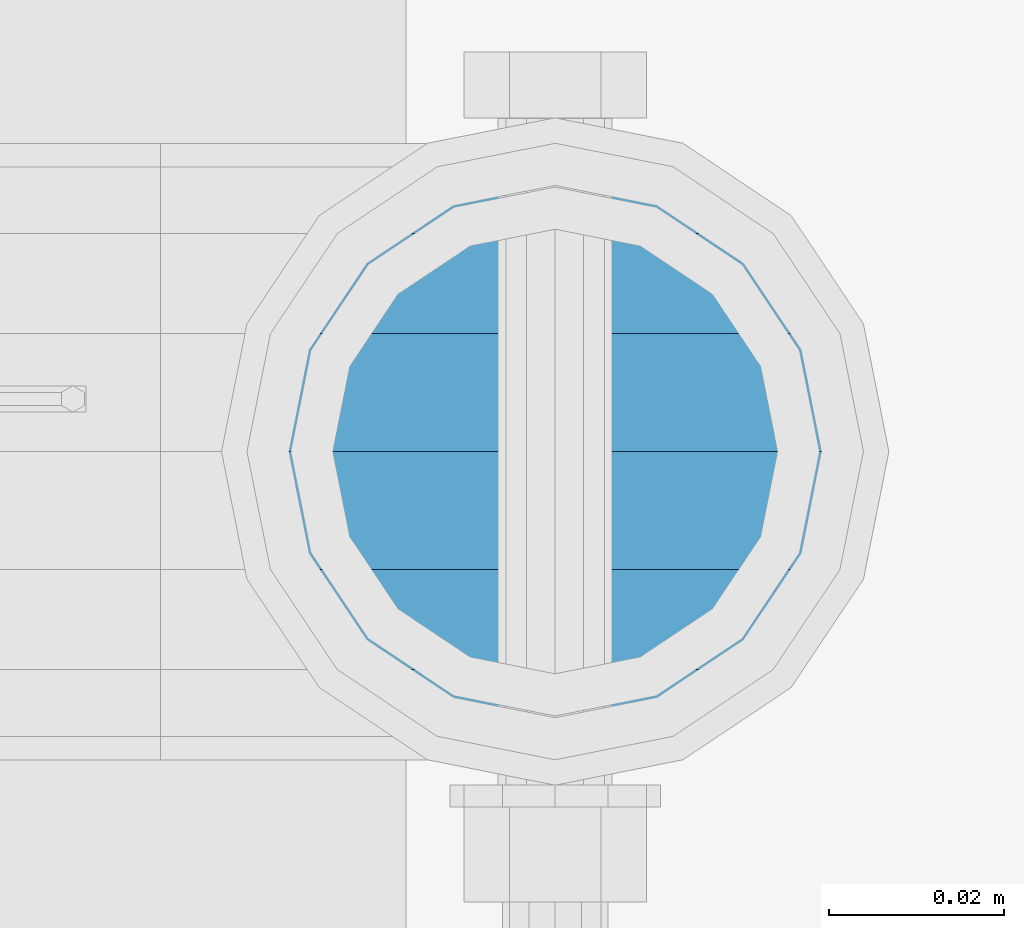
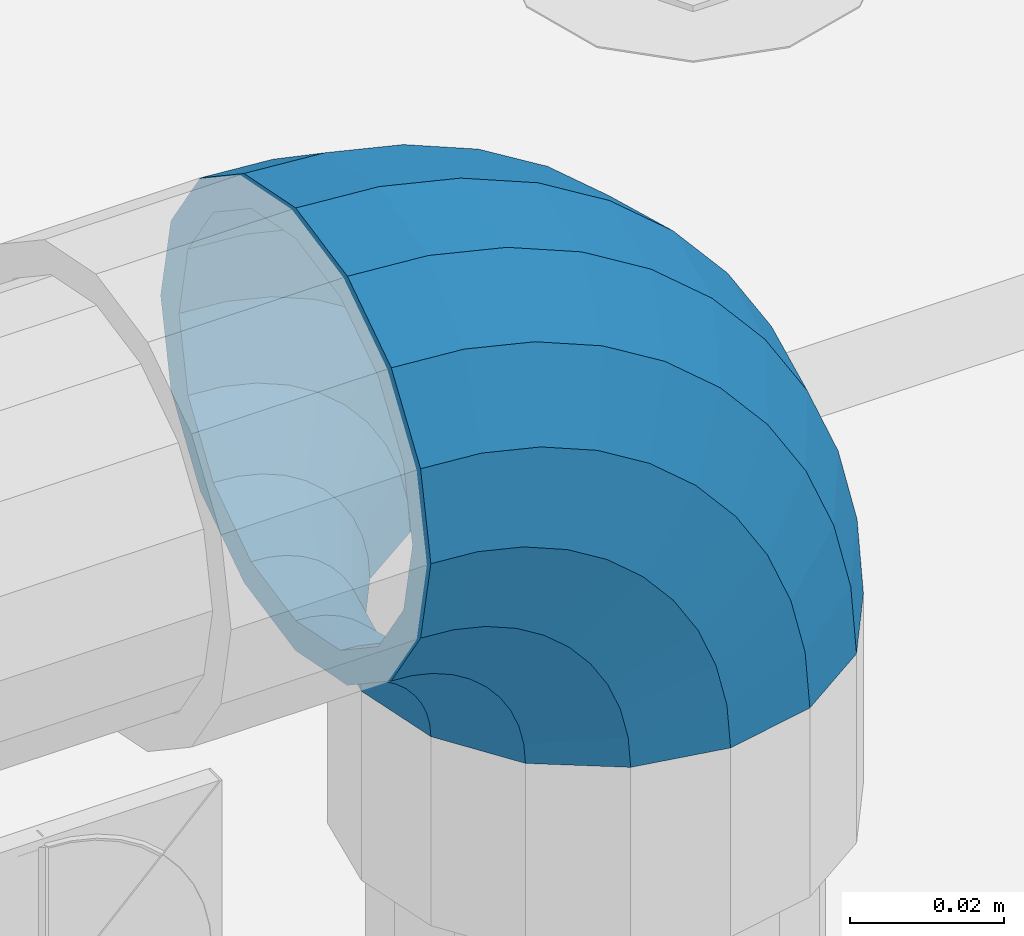
# One storey, part 126 of 193: 1 member.
"""IFC2X3 building model written with IfcOpenShell, lengths in millimetres."""

import ifcopenshell
import ifcopenshell.guid

model = None  # the IFC model being written
_history = None  # IfcOwnerHistory: only IFC2X3 demands one
_inside = {}  # id of a spatial element -> (the spatial element, [elements in it])
_under = {}  # id of a project, library or spatial element -> (it, [spatial elements below it])
_declared = {}  # id of a project -> (the project, [libraries it declares])
_typed = {}  # id of a type object -> (the type object, [elements of that type])
_made_of = {}  # id of a material, layer set ... -> (it, [elements and type objects made of it])


def new_model(schema):
    """Start an empty IFC model of exactly this schema.

    Asked for "IFC4X3", IfcOpenShell would pick the latest addendum, in which some entities
    have other attributes; the version numbers below select the first issue.
    IFC2X3 requires an IfcOwnerHistory on every rooted entity: one is made here for all.
    """
    global model, _history
    if schema == "IFC4X3":
        model = ifcopenshell.file(schema_version=(4, 3, 0, 0))
    else:
        model = ifcopenshell.file(schema=schema)
    _inside.clear()
    _under.clear()
    _declared.clear()
    _typed.clear()
    _made_of.clear()
    _history = None
    if model.schema == "IFC2X3":
        org = make("IfcOrganization", Name="unknown")
        user = make(
            "IfcPersonAndOrganization",
            ThePerson=make("IfcPerson", FamilyName="unknown"),
            TheOrganization=org,
        )
        app = make(
            "IfcApplication",
            ApplicationDeveloper=org,
            Version="unknown",
            ApplicationFullName="unknown",
            ApplicationIdentifier="unknown",
        )
        _history = make(
            "IfcOwnerHistory",
            OwningUser=user,
            OwningApplication=app,
            ChangeAction="ADDED",
            CreationDate=0,
        )
    return model


def make(cls, **values):
    """One entity of the class cls with the attributes given. An attribute that is None is left unset."""
    return model.create_entity(
        cls, **{name: value for name, value in values.items() if value is not None}
    )


def rooted(cls, **values):
    """An entity with a GlobalId (a new one), such as an element, a storey or a relation."""
    return make(cls, GlobalId=ifcopenshell.guid.new(), OwnerHistory=_history, **values)


def si_unit(unit_type, name, prefix=None):
    """IfcSIUnit, for example si_unit("LENGTHUNIT", "METRE", prefix="MILLI")."""
    return make("IfcSIUnit", UnitType=unit_type, Prefix=prefix, Name=name)


def assignment(units):
    """IfcUnitAssignment: the units of a project."""
    return None if units is None else make("IfcUnitAssignment", Units=units)


def point(xyz):
    """IfcCartesianPoint."""
    return None if xyz is None else make("IfcCartesianPoint", Coordinates=xyz)


def direction(xyz):
    """IfcDirection."""
    return None if xyz is None else make("IfcDirection", DirectionRatios=xyz)


def frame(location, z_axis=None, x_axis=None):
    """IfcAxis2Placement3D, a coordinate frame: its origin and axes. An axis left out is left unset."""
    return make(
        "IfcAxis2Placement3D",
        Location=point(location),
        Axis=direction(z_axis),
        RefDirection=direction(x_axis),
    )


def origin_with_axes():
    """The frame at (0, 0, 0) with the z axis (0, 0, 1) and the x axis (1, 0, 0) written out."""
    return frame((0.0, 0.0, 0.0), z_axis=(0.0, 0.0, 1.0), x_axis=(1.0, 0.0, 0.0))


def place(relative_to, where):
    """IfcLocalPlacement: puts the frame where relative to a parent placement (None: the world)."""
    return make(
        "IfcLocalPlacement", PlacementRelTo=relative_to, RelativePlacement=where
    )


def context(
    kind, dimensions, precision=None, world=None, true_north=None, identifier=None
):
    """IfcGeometricRepresentationContext, for example the 3D "Model" context."""
    return make(
        "IfcGeometricRepresentationContext",
        ContextIdentifier=identifier,
        ContextType=kind,
        CoordinateSpaceDimension=dimensions,
        Precision=precision,
        WorldCoordinateSystem=world,
        TrueNorth=true_north,
    )


def subcontext(parent, identifier, kind, view, scale=None):
    """IfcGeometricRepresentationSubContext, for example "Body" below "Model"."""
    return make(
        "IfcGeometricRepresentationSubContext",
        ContextIdentifier=identifier,
        ContextType=kind,
        ParentContext=parent,
        TargetScale=scale,
        TargetView=view,
    )


def project(units=None, contexts=None):
    """IfcProject with its units and contexts."""
    return rooted(
        "IfcProject",
        Name="project",
        RepresentationContexts=contexts,
        UnitsInContext=assignment(units),
    )


def spatial(cls, under=None, at=None, **own):
    """A site, building, storey or space (cls), placed at a placement, below another one or the project."""
    s = rooted(cls, ObjectPlacement=at, **own)
    if under is not None:
        _under.setdefault(under.id(), (under, []))[1].append(s)
    return s


def faces_of(points, faces, orient=None, outer=None):
    """IfcFace entities. A face is a list of loops; a loop is a list of indices into points, from 0.

    orient and outer hold one flag for each loop. By default every Orientation is true, the
    first loop of a face is its IfcFaceOuterBound and the others are IfcFaceBound.
    """
    made = []
    for i, loops in enumerate(faces):
        bounds = []
        for j, loop in enumerate(loops):
            is_outer = j == 0 if outer is None else outer[i][j]
            bounds.append(
                make(
                    "IfcFaceOuterBound" if is_outer else "IfcFaceBound",
                    Bound=make("IfcPolyLoop", Polygon=[points[k] for k in loop]),
                    Orientation=True if orient is None else orient[i][j],
                )
            )
        made.append(make("IfcFace", Bounds=bounds))
    return made


def faceted_brep(points, faces, orient=None, outer=None, voids=None):
    """IfcFacetedBrep: a solid bounded by flat faces; with voids (closed shells), ...WithVoids."""
    shared = [point(p) for p in points]
    hull = make("IfcClosedShell", CfsFaces=faces_of(shared, faces, orient, outer))
    if voids is None:
        return make("IfcFacetedBrep", Outer=hull)
    return make(
        "IfcFacetedBrepWithVoids",
        Outer=hull,
        Voids=[
            make(cls, CfsFaces=faces_of(shared, fs, o, b)) for cls, fs, o, b in voids
        ],
    )


def shape(context_of_items, identifier, shape_type, items):
    """IfcShapeRepresentation: the items that make up one representation, for example the "Body"."""
    return make(
        "IfcShapeRepresentation",
        ContextOfItems=context_of_items,
        RepresentationIdentifier=identifier,
        RepresentationType=shape_type,
        Items=items,
    )


def material(Name=None, Category=None):
    """IfcMaterial."""
    return make("IfcMaterial", Name=Name, Category=Category)


def made_of(thing, what):
    """Note that an element or type object is made of a material, layer set ...; save() writes the relation."""
    if what is not None:
        _made_of.setdefault(what.id(), (what, []))[1].append(thing)
    return thing


def type_object(cls, material=None, **own):
    """A type object (cls), such as IfcWallType, which elements share."""
    return made_of(rooted(cls, **own), material)


def element(
    cls,
    number,
    at=None,
    inside=None,
    cuts=None,
    type_object=None,
    material=None,
    context=None,
    identifier="Body",
    shape_type=None,
    held_by="IfcProductDefinitionShape",
    body=None,
    shapes=None,
    **own,
):
    """One element of the class cls, such as IfcWall. Its Tag is "e" and its number.

    at: its placement. inside: the storey or other place that contains it. cuts: it is an
    opening in that element (IfcRelVoidsElement). A single representation is given by context,
    identifier, shape_type and body (its items); several are given by shapes. held_by: the class
    of the entity that holds the representations. save() writes the other relations.
    """
    e = rooted(cls, Tag="e%d" % number, ObjectPlacement=at, **own)
    if body is not None:
        shapes = [shape(context, identifier, shape_type, body)]
    if shapes is not None:
        e.Representation = make(held_by, Representations=shapes)
    if inside is not None:
        _inside.setdefault(inside.id(), (inside, []))[1].append(e)
    if cuts is not None:
        rooted(
            "IfcRelVoidsElement", RelatingBuildingElement=cuts, RelatedOpeningElement=e
        )
    if type_object is not None:
        _typed.setdefault(type_object.id(), (type_object, []))[1].append(e)
    return made_of(e, material)


def aggregate(whole, parts):
    """IfcRelAggregates: a whole, such as a stair, and the parts it consists of."""
    return rooted("IfcRelAggregates", RelatingObject=whole, RelatedObjects=parts)


def save(model, path):
    """Write the relations noted so far, then the file.

    IfcRelAggregates (storeys below a building ...), IfcRelContainedInSpatialStructure (elements
    in a storey), IfcRelDefinesByType, IfcRelAssociatesMaterial and IfcRelDeclares: one each for
    every whole, place, type object, material and project.
    """
    for whole, parts in _under.values():
        aggregate(whole, parts)
    for where, things in _inside.values():
        rooted(
            "IfcRelContainedInSpatialStructure",
            RelatedElements=things,
            RelatingStructure=where,
        )
    for kind, things in _typed.values():
        rooted("IfcRelDefinesByType", RelatedObjects=things, RelatingType=kind)
    for what, things in _made_of.values():
        rooted("IfcRelAssociatesMaterial", RelatedObjects=things, RelatingMaterial=what)
    for by, libraries in _declared.values():
        rooted("IfcRelDeclares", RelatingContext=by, RelatedDefinitions=libraries)
    model.write(path)


model = new_model("IFC2X3")

# Units and contexts
model_context = context("Model", 3, precision=1e-05, world=origin_with_axes())
body_context = subcontext(model_context, "Body", "Model", "MODEL_VIEW")
ifc_project = project(units=[si_unit("LENGTHUNIT", "METRE", prefix="MILLI"), si_unit("AREAUNIT", "SQUARE_METRE"), si_unit("VOLUMEUNIT", "CUBIC_METRE"), si_unit("MASSUNIT", "GRAM", prefix="KILO"), si_unit("TIMEUNIT", "SECOND"), si_unit("PLANEANGLEUNIT", "RADIAN"), si_unit("SOLIDANGLEUNIT", "STERADIAN"), si_unit("THERMODYNAMICTEMPERATUREUNIT", "DEGREE_CELSIUS"), si_unit("LUMINOUSINTENSITYUNIT", "LUMEN")], contexts=[model_context])

# Site, building, storey
site_placement = place(None, origin_with_axes())
site = spatial("IfcSite", under=ifc_project, at=site_placement, CompositionType="ELEMENT")
building_placement = place(site_placement, origin_with_axes())
building = spatial("IfcBuilding", under=site, at=building_placement, Name="Standard", CompositionType="ELEMENT")
storey_placement = place(building_placement, origin_with_axes())
storey = spatial("IfcBuildingStorey", under=building, at=storey_placement, Name="Undefined", CompositionType="ELEMENT", Elevation=0.0)

# Member
ifc_material = material(Name="Misc_Undefined")
member_type = type_object("IfcMemberType", PredefinedType="NOTDEFINED")
member_placement = place(storey_placement, frame((-30223.0, 28664.5, 924.85), z_axis=(0.707106781186547, 0.0, 0.707106781186548), x_axis=(-0.707106781186548, 0.0, 0.707106781186548)))
element("IfcMember", 1, at=member_placement, inside=storey, type_object=member_type, material=ifc_material, context=body_context, shape_type="Brep", body=[
    faceted_brep([(0.0, -35.1500000000015, 0.0), (9.51152146007007, -32.4743655677703, -9.51152146007007), (13.2759578763398, -32.4743655677703, -6.2963890252795), (5.36946880023243, -35.1500000000015, 4.58595959347804), (17.5749999999971, -24.8548033587067, -17.5750000000007), (19.978755663109, -24.8548033587067, -15.5219987155651), (22.9628441077002, -13.4513226476338, -22.9628441077002), (24.4574219585229, -13.4513226476338, -21.6863540323939), (24.8548033587067, 0.0, -24.8548033587067), (26.0301204183124, 0.0, -23.850987758804), (22.9628441077002, 13.4513226476338, -22.9628441077002), (24.4574219585229, 13.4513226476338, -21.6863540323939), (17.5749999999971, 24.8548033587067, -17.5750000000007), (19.978755663109, 24.8548033587067, -15.5219987155651), (9.51152146007007, 32.4743655677703, -9.51152146007007), (13.2759578763398, 32.4743655677703, -6.2963890252795), (0.0, 35.1500000000015, 0.0), (5.36946880023243, 35.1500000000015, 4.58595959347804), (-9.51152146007007, 32.4743655677703, 9.51152146007007), (-2.53702027587133, 32.4743655677703, 15.4683082122356), (-17.5750000000007, 24.8548033587067, 17.5750000000007), (-9.23981806264419, 24.8548033587067, 24.6939179025212), (-22.9628441077039, 13.4513226476338, 22.9628441077002), (-13.718484358058, 13.4513226476338, 30.8582732193499), (-24.8548033587103, 0.0, 24.8548033587067), (-15.2911828178476, 0.0, 33.02290694576), (-22.9628441077039, -13.4513226476338, 22.9628441077002), (-13.718484358058, -13.4513226476338, 30.8582732193499), (-17.5750000000007, -24.8548033587067, 17.5750000000007), (-9.23981806264419, -24.8548033587067, 24.6939179025212), (-9.51152146007007, -32.4743655677703, 9.51152146007007), (-2.53702027587133, -32.4743655677703, 15.4683082122356), (0.0, -30.3499999999985, 0.0), (-8.2126508197216, -28.0397438117179, 8.21265081971796), (-1.45732902223972, -28.0397438117179, 13.9822406910389), (5.36946880023243, -30.3499999999985, 4.58595959347804), (-15.1749999999993, -21.46069080901, 15.1749999999993), (-7.24480876131565, -21.46069080901, 21.9480231689959), (-19.827092992, -11.614442172282, 19.827092992), (-11.1118790903529, -11.614442172282, 27.2705888550809), (-21.4606908090136, 0.0, 21.46069080901), (-12.4698136068437, 0.0, 29.139625372758), (-19.827092992, 11.614442172282, 19.827092992), (-11.1118790903529, 11.614442172282, 27.2705888550809), (-15.1749999999993, 21.46069080901, 15.1749999999993), (-7.24480876131565, 21.46069080901, 21.9480231689959), (-8.2126508197216, 28.0397438117179, 8.21265081971796), (-1.45732902223972, 28.0397438117179, 13.9822406910389), (0.0, 30.3499999999985, 0.0), (5.36946880023243, 30.3499999999985, 4.58595959347804), (8.21265081971796, 28.0397438117179, -8.2126508197216), (12.1962666227009, 28.0397438117179, -4.81032150408282), (15.1749999999956, 21.46069080901, -15.1749999999993), (17.9837463617769, 21.46069080901, -12.7761039820398), (19.8270929919963, 11.614442172282, -19.827092992), (21.8508166908177, 11.614442172282, -18.0986696681211), (21.46069080901, 0.0, -21.46069080901), (23.2087512073085, 0.0, -19.9677061858019), (19.8270929919963, -11.614442172282, -19.827092992), (21.8508166908177, -11.614442172282, -18.0986696681211), (15.1749999999956, -21.46069080901, -15.1749999999993), (17.9837463617769, -21.46069080901, -12.7761039820398), (8.21265081971796, -28.0397438117179, -8.2126508197216), (12.1962666227009, -28.0397438117179, -4.81032150408282), (17.4970053560683, -32.4743655677703, -3.70972780292141), (11.3902326651114, -35.1500000000015, 8.27548843508339), (22.6740772628618, -24.8548033587067, -13.8703035149447), (26.1332861179508, -13.4513226476338, -20.6593831546779), (27.3479987309584, 0.0, -23.0433908901396), (26.1332861179508, 13.4513226476338, -20.6593831546779), (22.6740772628618, 24.8548033587067, -13.8703035149447), (17.4970053560683, 32.4743655677703, -3.70972780292141), (11.3902326651114, 35.1500000000015, 8.27548843508339), (5.28345997415818, 32.4743655677703, 20.2607046730882), (0.106388067368243, 24.8548033587067, 30.4212803851115), (-3.35282078772434, 13.4513226476338, 37.2103600248483), (-4.56753340073192, 0.0, 39.5943677603027), (-3.35282078772434, -13.4513226476338, 37.2103600248483), (0.106388067368243, -24.8548033587067, 30.4212803851115), (5.28345997415818, -32.4743655677703, 20.2607046730882), (6.11738625912403, -28.0397438117179, 18.6240321853948), (11.3902326651114, -30.3499999999985, 8.27548843508339), (1.6472829199738, -21.46069080901, 27.3971039594981), (-1.3395446405375, -11.614442172282, 33.259083107896), (-2.38837900198268, 0.0, 35.3175364441995), (-1.3395446405375, 11.614442172282, 33.259083107896), (1.6472829199738, 21.46069080901, 27.3971039594981), (6.11738625912403, 28.0397438117179, 18.6240321853948), (11.3902326651114, 30.3499999999985, 8.27548843508339), (16.6630790711024, 28.0397438117179, -2.07305531522434), (21.1331824102526, 21.46069080901, -10.8461270893349), (24.1200099707639, 11.614442172282, -16.7081062377292), (25.1688443322091, 0.0, -18.7665595740327), (24.1200099707639, -11.614442172282, -16.7081062377292), (21.1331824102526, -21.46069080901, -10.8461270893349), (16.6630790711024, -28.0397438117179, -2.07305531522434), (22.070727701459, -32.4743655677703, -1.81522997693173), (17.9140404065183, -35.1500000000015, 10.9777380798878), (25.5945970362081, -24.8548033587067, -12.6605846156453), (27.9491712485069, -13.4513226476338, -19.9072189058934), (28.7759877587996, 0.0, -22.4518984678871), (27.9491712485069, 13.4513226476338, -19.9072189058934), (25.5945970362081, 24.8548033587067, -12.6605846156453), (22.070727701459, 32.4743655677703, -1.81522997693173), (17.9140404065183, 35.1500000000015, 10.9777380798878), (13.7573531115813, 32.4743655677703, 23.7707061367037), (10.2334837768358, 24.8548033587067, 34.6160607754209), (7.87890956453339, 13.4513226476338, 41.8626950656653), (7.05209305424069, 0.0, 44.407374627659), (7.87890956453339, -13.4513226476338, 41.8626950656653), (10.2334837768358, -24.8548033587067, 34.6160607754209), (13.7573531115813, -32.4743655677703, 23.7707061367037), (14.3249803951003, -28.0397438117179, 22.0237289909674), (17.9140404065183, -30.3499999999985, 10.9777380798878), (11.2823222355109, -21.46069080901, 31.3880679179965), (9.24928305077992, -11.614442172282, 37.6451191472661), (8.53537462723762, 0.0, 39.8423033494473), (9.24928305077992, 11.614442172282, 37.6451191472661), (11.2823222355109, 21.46069080901, 31.3880679179965), (14.3249803951003, 28.0397438117179, 22.0237289909674), (17.9140404065183, 30.3499999999985, 10.9777380798878), (21.50310041794, 28.0397438117179, -0.0682528311917849), (24.545758577533, 21.46069080901, -9.43259175821731), (26.5787977622604, 11.614442172282, -15.6896429874942), (27.2927061858027, 0.0, -17.8868271896717), (26.5787977622604, -11.614442172282, -15.6896429874942), (24.545758577533, -21.46069080901, -9.43259175821731), (21.50310041794, -28.0397438117179, -0.0682528311917849), (26.8845046890456, -32.4743655677703, -0.659544371261291), (24.7802542265854, -35.1500000000015, 12.6261701733893), (28.6684020936846, -24.8548033587067, -11.9226293117936), (29.8603642316994, -13.4513226476338, -19.4483820661262), (30.2789256727447, 0.0, -22.0910749985305), (29.8603642316994, 13.4513226476338, -19.4483820661262), (28.6684020936846, 24.8548033587067, -11.9226293117936), (26.8845046890456, 32.4743655677703, -0.659544371261291), (24.7802542265854, 35.1500000000015, 12.6261701733893), (22.6760037641179, 32.4743655677703, 25.9118847180362), (20.8921063594826, 24.8548033587067, 37.1749696585684), (19.7001442214678, 13.4513226476338, 44.7007224129011), (19.2815827804188, 0.0, 47.3434153453054), (19.7001442214678, -13.4513226476338, 44.7007224129011), (20.8921063594826, -24.8548033587067, 37.1749696585684), (22.6760037641179, -32.4743655677703, 25.9118847180362), (22.963355178621, -28.0397438117179, 24.0976192894668), (24.7802542265854, -30.3499999999985, 12.6261701733893), (21.4230625404816, -21.46069080901, 33.8226442665655), (20.3938719035323, -11.614442172282, 40.3206982094962), (20.032468212612, 0.0, 42.6025113104479), (20.3938719035323, 11.614442172282, 40.3206982094962), (21.4230625404816, 21.46069080901, 33.8226442665655), (22.963355178621, 28.0397438117179, 24.0976192894668), (24.7802542265854, 30.3499999999985, 12.6261701733893), (26.5971532745461, 28.0397438117179, 1.15472105730805), (28.1374459126819, 21.46069080901, -8.5703039197906), (29.1666365496349, 11.614442172282, -15.0683578627213), (29.5280402405551, 0.0, -17.3501709636766), (29.1666365496349, -11.614442172282, -15.0683578627213), (28.1374459126819, -21.46069080901, -8.5703039197906), (26.5971532745461, -28.0397438117179, 1.15472105730805), (31.8198051533946, -32.4743655677703, -0.271127801028342), (31.8198051533946, -35.1500000000015, 13.1801948466054), (31.8198051533946, -24.8548033587067, -11.6746085121013), (31.8198051533946, -13.4513226476338, -19.2941707211648), (31.8198051533909, 0.0, -21.969805153396), (31.8198051533946, 13.4513226476338, -19.2941707211648), (31.8198051533946, 24.8548033587067, -11.6746085121013), (31.8198051533946, 32.4743655677703, -0.271127801028342), (31.8198051533946, 35.1500000000015, 13.1801948466054), (31.8198051533946, 32.4743655677703, 26.6315174942392), (31.8198051533909, 24.8548033587067, 38.0349982053121), (31.8198051533946, 13.4513226476338, 45.6545604143794), (31.8198051533946, 0.0, 48.3301948466069), (31.8198051533946, -13.4513226476338, 45.6545604143794), (31.8198051533909, -24.8548033587067, 38.0349982053121), (31.8198051533946, -32.4743655677703, 26.6315174942392), (31.8198051533909, -28.0397438117179, 24.7946370188874), (31.8198051533946, -30.3499999999985, 13.1801948466054), (31.8198051533946, -21.46069080901, 34.6408856556154), (31.8198051533946, -11.614442172282, 41.219938658327), (31.8198051533909, 0.0, 43.530194846604), (31.8198051533946, 11.614442172282, 41.219938658327), (31.8198051533946, 21.46069080901, 34.6408856556154), (31.8198051533909, 28.0397438117179, 24.7946370188874), (31.8198051533946, 30.3499999999985, 13.1801948466054), (31.8198051533946, 28.0397438117179, 1.56575267432709), (31.8198051533909, 21.46069080901, -8.28049596240453), (31.8198051533946, 11.614442172282, -14.8595489651125), (31.8198051533909, 0.0, -17.1698051533931), (31.8198051533946, -11.614442172282, -14.8595489651125), (31.8198051533909, -21.46069080901, -8.28049596240453), (31.8198051533946, -28.0397438117179, 1.56575267432709), (36.7551056177363, -32.4743655677703, -0.659544371264928), (38.8593560802037, -35.1500000000015, 12.6261701733893), (34.9712082131009, -24.8548033587067, -11.9226293117936), (33.7792460750898, -13.4513226476338, -19.4483820661226), (33.3606846340372, 0.0, -22.0910749985305), (33.7792460750898, 13.4513226476338, -19.4483820661226), (34.9712082131009, 24.8548033587067, -11.9226293117936), (36.7551056177363, 32.4743655677703, -0.659544371264928), (38.8593560802037, 35.1500000000015, 12.6261701733893), (40.9636065426712, 32.4743655677703, 25.9118847180362), (42.7475039473065, 24.8548033587067, 37.1749696585684), (43.9394660853177, 13.4513226476338, 44.7007224128974), (44.3580275263666, 0.0, 47.343415345309), (43.9394660853177, -13.4513226476338, 44.7007224128974), (42.7475039473065, -24.8548033587067, 37.1749696585684), (40.9636065426712, -32.4743655677703, 25.9118847180362), (40.6762551281645, -28.0397438117179, 24.0976192894632), (38.8593560802037, -30.3499999999985, 12.6261701733893), (42.2165477663038, -21.46069080901, 33.8226442665655), (43.2457384032568, -11.614442172282, 40.3206982094962), (43.6071420941771, 0.0, 42.6025113104515), (43.2457384032568, 11.614442172282, 40.3206982094962), (42.2165477663038, 21.46069080901, 33.8226442665655), (40.6762551281645, 28.0397438117179, 24.0976192894632), (38.8593560802037, 30.3499999999985, 12.6261701733893), (37.042457032243, 28.0397438117179, 1.15472105730805), (35.5021643941, 21.46069080901, -8.5703039197906), (34.4729737571543, 11.614442172282, -15.0683578627213), (34.1115700662303, 0.0, -17.3501709636766), (34.4729737571543, -11.614442172282, -15.0683578627213), (35.5021643941, -21.46069080901, -8.5703039197906), (37.042457032243, -28.0397438117179, 1.15472105730805), (41.5688826053265, -32.4743655677703, -1.81522997693173), (45.7255699002671, -35.1500000000015, 10.9777380798878), (38.0450132705773, -24.8548033587067, -12.6605846156453), (35.6904390582786, -13.4513226476338, -19.9072189058897), (34.8636225479859, 0.0, -22.4518984678834), (35.6904390582786, 13.4513226476338, -19.9072189058897), (38.0450132705773, 24.8548033587067, -12.6605846156453), (41.5688826053265, 32.4743655677703, -1.81522997693173), (45.7255699002671, 35.1500000000015, 10.9777380798878), (49.8822571952041, 32.4743655677703, 23.7707061367073), (53.4061265299533, 24.8548033587067, 34.6160607754173), (55.7607007422557, 13.4513226476338, 41.862695065669), (56.5875172525448, 0.0, 44.4073746276626), (55.7607007422557, -13.4513226476338, 41.862695065669), (53.4061265299533, -24.8548033587067, 34.6160607754173), (49.8822571952041, -32.4743655677703, 23.7707061367073), (49.3146299116852, -28.0397438117179, 22.0237289909674), (45.7255699002671, -30.3499999999985, 10.9777380798878), (52.3572880712782, -21.46069080901, 31.3880679179929), (54.3903272560092, -11.614442172282, 37.6451191472697), (55.1042356795442, 0.0, 39.8423033494437), (54.3903272560092, 11.614442172282, 37.6451191472697), (52.3572880712782, 21.46069080901, 31.3880679179929), (49.3146299116852, 28.0397438117179, 22.0237289909674), (45.7255699002671, 30.3499999999985, 10.9777380798878), (42.1365098888455, 28.0397438117179, -0.0682528311954229), (39.0938517292525, 21.46069080901, -9.43259175821731), (37.0608125445215, 11.614442172282, -15.6896429874905), (36.3469041209864, 0.0, -17.8868271896681), (37.0608125445215, -11.614442172282, -15.6896429874905), (39.0938517292525, -21.46069080901, -9.43259175821731), (42.1365098888455, -28.0397438117179, -0.0682528311954229), (46.1426049507172, -32.4743655677703, -3.70972780292141), (52.2493776416704, -35.1500000000015, 8.27548843508339), (40.9655330439236, -24.8548033587067, -13.8703035149447), (37.5063241888347, -13.4513226476338, -20.6593831546816), (36.2916115758235, 0.0, -23.0433908901359), (37.5063241888347, 13.4513226476338, -20.6593831546816), (40.9655330439236, 24.8548033587067, -13.8703035149447), (46.1426049507172, 32.4743655677703, -3.70972780292141), (52.2493776416704, 35.1500000000015, 8.27548843508339), (58.3561503326309, 32.4743655677703, 20.2607046730882), (63.5332222394209, 24.8548033587067, 30.4212803851115), (66.9924310945134, 13.4513226476338, 37.2103600248447), (68.2071437075174, 0.0, 39.5943677603027), (66.9924310945134, -13.4513226476338, 37.2103600248447), (63.5332222394209, -24.8548033587067, 30.4212803851115), (58.3561503326309, -32.4743655677703, 20.2607046730882), (57.5222240476651, -28.0397438117179, 18.6240321853911), (52.2493776416704, -30.3499999999985, 8.27548843508339), (61.9923273868117, -21.46069080901, 27.3971039595017), (64.9791549473193, -11.614442172282, 33.259083107896), (66.0279893087682, 0.0, 35.3175364441995), (64.9791549473193, 11.614442172282, 33.259083107896), (61.9923273868117, 21.46069080901, 27.3971039595017), (57.5222240476651, 28.0397438117179, 18.6240321853911), (52.2493776416704, 30.3499999999985, 8.27548843508339), (46.9765312356831, 28.0397438117179, -2.07305531522798), (42.5064278965328, 21.46069080901, -10.8461270893386), (39.5196003360215, 11.614442172282, -16.7081062377292), (38.4707659745764, 0.0, -18.7665595740364), (39.5196003360215, -11.614442172282, -16.7081062377292), (42.5064278965328, -21.46069080901, -10.8461270893386), (46.9765312356831, -28.0397438117179, -2.07305531522798), (50.3636524304493, -32.4743655677703, -6.29638902527586), (58.2701415065567, -35.1500000000015, 4.58595959347804), (43.6608546436801, -24.8548033587067, -15.5219987155615), (39.1821883482626, -13.4513226476338, -21.6863540323939), (37.6094898884767, 0.0, -23.8509877588003), (39.1821883482626, 13.4513226476338, -21.6863540323939), (43.6608546436801, 24.8548033587067, -15.5219987155615), (50.3636524304493, 32.4743655677703, -6.29638902527586), (58.2701415065567, 35.1500000000015, 4.58595959347804), (66.1766305826604, 32.4743655677703, 15.4683082122319), (72.8794283694333, 24.8548033587067, 24.6939179025212), (77.3580946648435, 13.4513226476338, 30.8582732193499), (78.9307931246331, 0.0, 33.0229069457564), (77.3580946648435, -13.4513226476338, 30.8582732193499), (72.8794283694333, -24.8548033587067, 24.6939179025212), (66.1766305826604, -32.4743655677703, 15.4683082122319), (65.0969393290252, -28.0397438117179, 13.9822406910425), (58.2701415065567, -30.3499999999985, 4.58595959347804), (70.8844190680975, -21.46069080901, 21.9480231689959), (74.751489397142, -11.614442172282, 27.2705888550772), (76.1094239136291, 0.0, 29.1396253727617), (74.751489397142, 11.614442172282, 27.2705888550772), (70.8844190680975, 21.46069080901, 21.9480231689959), (65.0969393290252, 28.0397438117179, 13.9822406910425), (58.2701415065567, 30.3499999999985, 4.58595959347804), (51.4433436840845, 28.0397438117179, -4.81032150407918), (45.6558639450086, 21.46069080901, -12.7761039820361), (41.7887936159677, 11.614442172282, -18.0986696681211), (40.4308590994769, 0.0, -19.9677061857983), (41.7887936159677, -11.614442172282, -18.0986696681211), (45.6558639450086, -21.46069080901, -12.7761039820361), (51.4433436840845, -28.0397438117179, -4.81032150407918), (54.128088846719, -32.4743655677703, -9.51152146007007), (63.6396103067891, -35.1500000000015, 0.0), (46.0646103067884, -24.8548033587067, -17.5750000000007), (40.6767661990889, -13.4513226476338, -22.9628441077002), (38.7848069480824, 0.0, -24.8548033587067), (40.6767661990889, 13.4513226476338, -22.9628441077002), (46.0646103067884, 24.8548033587067, -17.5750000000007), (54.128088846719, 32.4743655677703, -9.51152146007007), (63.6396103067891, 35.1500000000015, 0.0), (73.1511317668592, 32.4743655677703, 9.51152146007007), (81.2146103067898, 24.8548033587067, 17.5750000000007), (86.602454414493, 13.4513226476338, 22.9628441077039), (88.4944136654958, 0.0, 24.8548033587067), (86.602454414493, -13.4513226476338, 22.9628441077039), (81.2146103067898, -24.8548033587067, 17.5750000000007), (73.1511317668592, -32.4743655677703, 9.51152146007007), (71.8522611265071, -28.0397438117179, 8.21265081971796), (63.6396103067891, -30.3499999999985, 0.0), (78.8146103067884, -21.46069080901, 15.1749999999993), (83.4667032987891, -11.614442172282, 19.827092992), (85.1003011158027, 0.0, 21.4606908090136), (83.4667032987891, 11.614442172282, 19.827092992), (78.8146103067884, 21.46069080901, 15.1749999999993), (71.8522611265071, 28.0397438117179, 8.21265081971796), (63.6396103067891, 30.3499999999985, 0.0), (55.4269594870711, 28.0397438117179, -8.21265081971796), (48.4646103067898, 21.46069080901, -15.1749999999993), (43.8125173147891, 11.614442172282, -19.8270929919963), (42.1789194977791, 0.0, -21.46069080901), (43.8125173147891, -11.614442172282, -19.8270929919963), (48.4646103067898, -21.46069080901, -15.1749999999993), (55.4269594870711, -28.0397438117179, -8.21265081971796)], [[[0, 1, 2, 3]], [[1, 4, 5, 2]], [[4, 6, 7, 5]], [[6, 8, 9, 7]], [[8, 10, 11, 9]], [[10, 12, 13, 11]], [[12, 14, 15, 13]], [[14, 16, 17, 15]], [[16, 18, 19, 17]], [[18, 20, 21, 19]], [[20, 22, 23, 21]], [[22, 24, 25, 23]], [[24, 26, 27, 25]], [[26, 28, 29, 27]], [[28, 30, 31, 29]], [[30, 0, 3, 31]], [[32, 33, 34, 35]], [[33, 36, 37, 34]], [[36, 38, 39, 37]], [[38, 40, 41, 39]], [[40, 42, 43, 41]], [[42, 44, 45, 43]], [[44, 46, 47, 45]], [[46, 48, 49, 47]], [[48, 50, 51, 49]], [[50, 52, 53, 51]], [[52, 54, 55, 53]], [[54, 56, 57, 55]], [[56, 58, 59, 57]], [[58, 60, 61, 59]], [[60, 62, 63, 61]], [[62, 32, 35, 63]], [[30, 28, 26, 24, 22, 20, 18, 16, 14, 12, 10, 8, 6, 4, 1, 0], [62, 60, 58, 56, 54, 52, 50, 48, 46, 44, 42, 40, 38, 36, 33, 32]], [[3, 2, 64, 65]], [[2, 5, 66, 64]], [[5, 7, 67, 66]], [[7, 9, 68, 67]], [[9, 11, 69, 68]], [[11, 13, 70, 69]], [[13, 15, 71, 70]], [[15, 17, 72, 71]], [[17, 19, 73, 72]], [[19, 21, 74, 73]], [[21, 23, 75, 74]], [[23, 25, 76, 75]], [[25, 27, 77, 76]], [[27, 29, 78, 77]], [[29, 31, 79, 78]], [[31, 3, 65, 79]], [[35, 34, 80, 81]], [[34, 37, 82, 80]], [[37, 39, 83, 82]], [[39, 41, 84, 83]], [[41, 43, 85, 84]], [[43, 45, 86, 85]], [[45, 47, 87, 86]], [[47, 49, 88, 87]], [[49, 51, 89, 88]], [[51, 53, 90, 89]], [[53, 55, 91, 90]], [[55, 57, 92, 91]], [[57, 59, 93, 92]], [[59, 61, 94, 93]], [[61, 63, 95, 94]], [[63, 35, 81, 95]], [[65, 64, 96, 97]], [[64, 66, 98, 96]], [[66, 67, 99, 98]], [[67, 68, 100, 99]], [[68, 69, 101, 100]], [[69, 70, 102, 101]], [[70, 71, 103, 102]], [[71, 72, 104, 103]], [[72, 73, 105, 104]], [[73, 74, 106, 105]], [[74, 75, 107, 106]], [[75, 76, 108, 107]], [[76, 77, 109, 108]], [[77, 78, 110, 109]], [[78, 79, 111, 110]], [[79, 65, 97, 111]], [[81, 80, 112, 113]], [[80, 82, 114, 112]], [[82, 83, 115, 114]], [[83, 84, 116, 115]], [[84, 85, 117, 116]], [[85, 86, 118, 117]], [[86, 87, 119, 118]], [[87, 88, 120, 119]], [[88, 89, 121, 120]], [[89, 90, 122, 121]], [[90, 91, 123, 122]], [[91, 92, 124, 123]], [[92, 93, 125, 124]], [[93, 94, 126, 125]], [[94, 95, 127, 126]], [[95, 81, 113, 127]], [[97, 96, 128, 129]], [[96, 98, 130, 128]], [[98, 99, 131, 130]], [[99, 100, 132, 131]], [[100, 101, 133, 132]], [[101, 102, 134, 133]], [[102, 103, 135, 134]], [[103, 104, 136, 135]], [[104, 105, 137, 136]], [[105, 106, 138, 137]], [[106, 107, 139, 138]], [[107, 108, 140, 139]], [[108, 109, 141, 140]], [[109, 110, 142, 141]], [[110, 111, 143, 142]], [[111, 97, 129, 143]], [[113, 112, 144, 145]], [[112, 114, 146, 144]], [[114, 115, 147, 146]], [[115, 116, 148, 147]], [[116, 117, 149, 148]], [[117, 118, 150, 149]], [[118, 119, 151, 150]], [[119, 120, 152, 151]], [[120, 121, 153, 152]], [[121, 122, 154, 153]], [[122, 123, 155, 154]], [[123, 124, 156, 155]], [[124, 125, 157, 156]], [[125, 126, 158, 157]], [[126, 127, 159, 158]], [[127, 113, 145, 159]], [[129, 128, 160, 161]], [[128, 130, 162, 160]], [[130, 131, 163, 162]], [[131, 132, 164, 163]], [[132, 133, 165, 164]], [[133, 134, 166, 165]], [[134, 135, 167, 166]], [[135, 136, 168, 167]], [[136, 137, 169, 168]], [[137, 138, 170, 169]], [[138, 139, 171, 170]], [[139, 140, 172, 171]], [[140, 141, 173, 172]], [[141, 142, 174, 173]], [[142, 143, 175, 174]], [[143, 129, 161, 175]], [[145, 144, 176, 177]], [[144, 146, 178, 176]], [[146, 147, 179, 178]], [[147, 148, 180, 179]], [[148, 149, 181, 180]], [[149, 150, 182, 181]], [[150, 151, 183, 182]], [[151, 152, 184, 183]], [[152, 153, 185, 184]], [[153, 154, 186, 185]], [[154, 155, 187, 186]], [[155, 156, 188, 187]], [[156, 157, 189, 188]], [[157, 158, 190, 189]], [[158, 159, 191, 190]], [[159, 145, 177, 191]], [[161, 160, 192, 193]], [[160, 162, 194, 192]], [[162, 163, 195, 194]], [[163, 164, 196, 195]], [[164, 165, 197, 196]], [[165, 166, 198, 197]], [[166, 167, 199, 198]], [[167, 168, 200, 199]], [[168, 169, 201, 200]], [[169, 170, 202, 201]], [[170, 171, 203, 202]], [[171, 172, 204, 203]], [[172, 173, 205, 204]], [[173, 174, 206, 205]], [[174, 175, 207, 206]], [[175, 161, 193, 207]], [[177, 176, 208, 209]], [[176, 178, 210, 208]], [[178, 179, 211, 210]], [[179, 180, 212, 211]], [[180, 181, 213, 212]], [[181, 182, 214, 213]], [[182, 183, 215, 214]], [[183, 184, 216, 215]], [[184, 185, 217, 216]], [[185, 186, 218, 217]], [[186, 187, 219, 218]], [[187, 188, 220, 219]], [[188, 189, 221, 220]], [[189, 190, 222, 221]], [[190, 191, 223, 222]], [[191, 177, 209, 223]], [[193, 192, 224, 225]], [[192, 194, 226, 224]], [[194, 195, 227, 226]], [[195, 196, 228, 227]], [[196, 197, 229, 228]], [[197, 198, 230, 229]], [[198, 199, 231, 230]], [[199, 200, 232, 231]], [[200, 201, 233, 232]], [[201, 202, 234, 233]], [[202, 203, 235, 234]], [[203, 204, 236, 235]], [[204, 205, 237, 236]], [[205, 206, 238, 237]], [[206, 207, 239, 238]], [[207, 193, 225, 239]], [[209, 208, 240, 241]], [[208, 210, 242, 240]], [[210, 211, 243, 242]], [[211, 212, 244, 243]], [[212, 213, 245, 244]], [[213, 214, 246, 245]], [[214, 215, 247, 246]], [[215, 216, 248, 247]], [[216, 217, 249, 248]], [[217, 218, 250, 249]], [[218, 219, 251, 250]], [[219, 220, 252, 251]], [[220, 221, 253, 252]], [[221, 222, 254, 253]], [[222, 223, 255, 254]], [[223, 209, 241, 255]], [[225, 224, 256, 257]], [[224, 226, 258, 256]], [[226, 227, 259, 258]], [[227, 228, 260, 259]], [[228, 229, 261, 260]], [[229, 230, 262, 261]], [[230, 231, 263, 262]], [[231, 232, 264, 263]], [[232, 233, 265, 264]], [[233, 234, 266, 265]], [[234, 235, 267, 266]], [[235, 236, 268, 267]], [[236, 237, 269, 268]], [[237, 238, 270, 269]], [[238, 239, 271, 270]], [[239, 225, 257, 271]], [[241, 240, 272, 273]], [[240, 242, 274, 272]], [[242, 243, 275, 274]], [[243, 244, 276, 275]], [[244, 245, 277, 276]], [[245, 246, 278, 277]], [[246, 247, 279, 278]], [[247, 248, 280, 279]], [[248, 249, 281, 280]], [[249, 250, 282, 281]], [[250, 251, 283, 282]], [[251, 252, 284, 283]], [[252, 253, 285, 284]], [[253, 254, 286, 285]], [[254, 255, 287, 286]], [[255, 241, 273, 287]], [[257, 256, 288, 289]], [[256, 258, 290, 288]], [[258, 259, 291, 290]], [[259, 260, 292, 291]], [[260, 261, 293, 292]], [[261, 262, 294, 293]], [[262, 263, 295, 294]], [[263, 264, 296, 295]], [[264, 265, 297, 296]], [[265, 266, 298, 297]], [[266, 267, 299, 298]], [[267, 268, 300, 299]], [[268, 269, 301, 300]], [[269, 270, 302, 301]], [[270, 271, 303, 302]], [[271, 257, 289, 303]], [[273, 272, 304, 305]], [[272, 274, 306, 304]], [[274, 275, 307, 306]], [[275, 276, 308, 307]], [[276, 277, 309, 308]], [[277, 278, 310, 309]], [[278, 279, 311, 310]], [[279, 280, 312, 311]], [[280, 281, 313, 312]], [[281, 282, 314, 313]], [[282, 283, 315, 314]], [[283, 284, 316, 315]], [[284, 285, 317, 316]], [[285, 286, 318, 317]], [[286, 287, 319, 318]], [[287, 273, 305, 319]], [[289, 288, 320, 321]], [[288, 290, 322, 320]], [[290, 291, 323, 322]], [[291, 292, 324, 323]], [[292, 293, 325, 324]], [[293, 294, 326, 325]], [[294, 295, 327, 326]], [[295, 296, 328, 327]], [[296, 297, 329, 328]], [[297, 298, 330, 329]], [[298, 299, 331, 330]], [[299, 300, 332, 331]], [[300, 301, 333, 332]], [[301, 302, 334, 333]], [[302, 303, 335, 334]], [[303, 289, 321, 335]], [[305, 304, 336, 337]], [[304, 306, 338, 336]], [[306, 307, 339, 338]], [[307, 308, 340, 339]], [[308, 309, 341, 340]], [[309, 310, 342, 341]], [[310, 311, 343, 342]], [[311, 312, 344, 343]], [[312, 313, 345, 344]], [[313, 314, 346, 345]], [[314, 315, 347, 346]], [[315, 316, 348, 347]], [[316, 317, 349, 348]], [[317, 318, 350, 349]], [[318, 319, 351, 350]], [[319, 305, 337, 351]], [[322, 323, 324, 325, 326, 327, 328, 329, 330, 331, 332, 333, 334, 335, 321, 320], [338, 339, 340, 341, 342, 343, 344, 345, 346, 347, 348, 349, 350, 351, 337, 336]]]),
])

save(model, "model.ifc")
